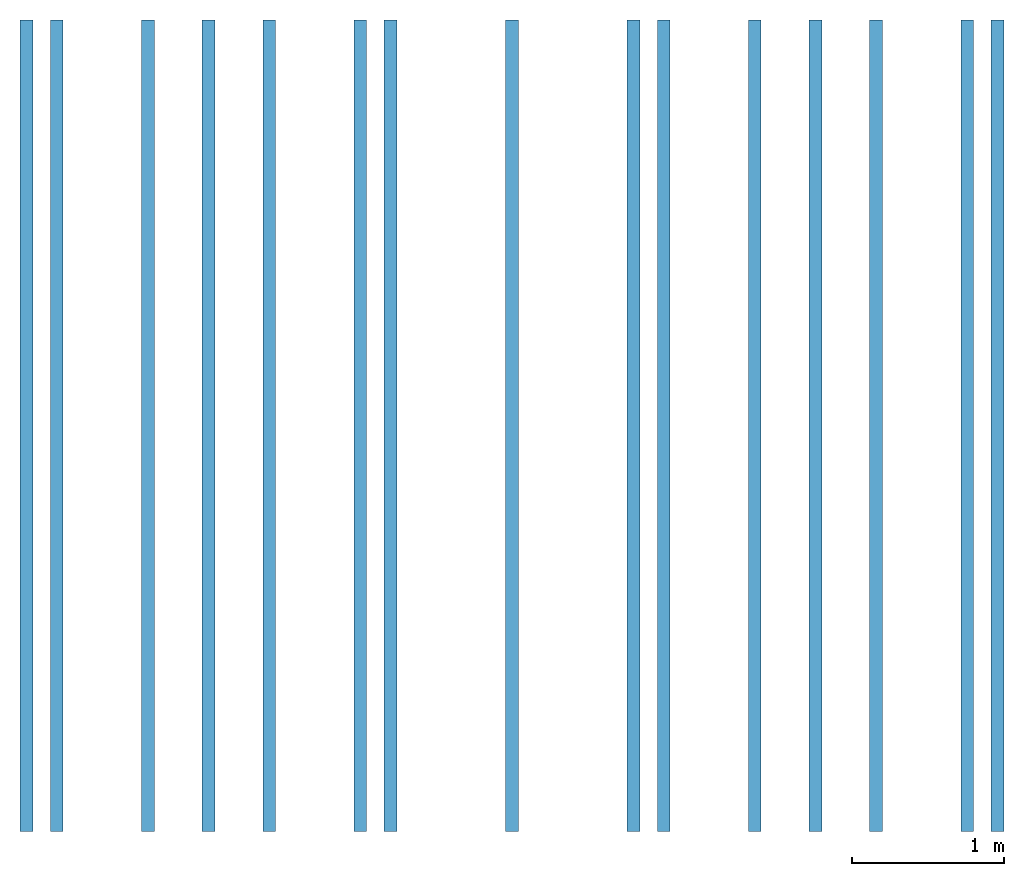
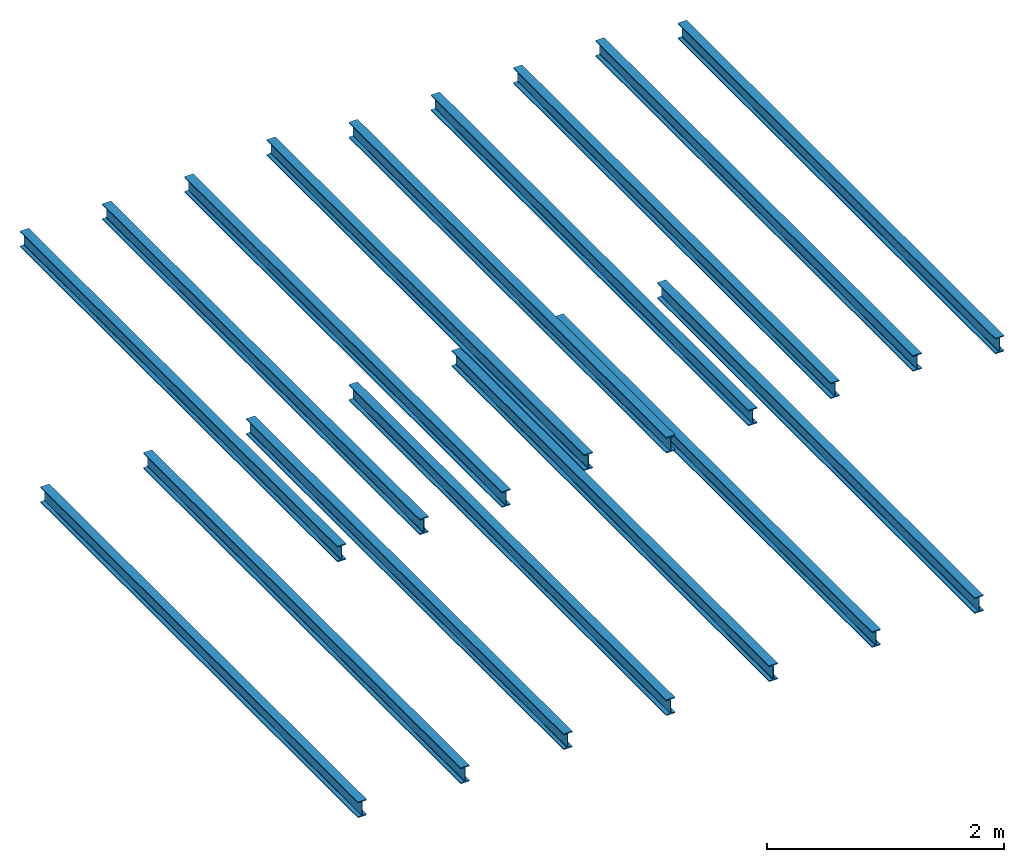
# One storey: 16 beams.
"""IFC2X3 building model written with IfcOpenShell, lengths in millimetres."""

from ifc_helpers import new_model, entity, si_unit, converted_unit, derived_unit, direction, frame, frame_2d, origin, place, context, subcontext, project, spatial, i_section, extrude, material, element, save


model = new_model("IFC2X3")

# Units and contexts
model_context = context("Model", 3, precision=0.01, world=origin(), true_north=direction((6.12303176911189e-17, 1.0)))
body_context = subcontext(model_context, "Body", "Model", "MODEL_VIEW")
ifc_project = project(units=[si_unit("LENGTHUNIT", "METRE", prefix="MILLI"), si_unit("AREAUNIT", "SQUARE_METRE"), si_unit("VOLUMEUNIT", "CUBIC_METRE"), converted_unit("PLANEANGLEUNIT", "DEGREE", entity("IfcRatioMeasure", 0.0174532925199433), si_unit("PLANEANGLEUNIT", "RADIAN"), dimensions=[0, 0, 0, 0, 0, 0, 0]), si_unit("MASSUNIT", "GRAM", prefix="KILO"), si_unit("TIMEUNIT", "SECOND"), si_unit("FREQUENCYUNIT", "HERTZ"), si_unit("THERMODYNAMICTEMPERATUREUNIT", "DEGREE_CELSIUS"), derived_unit("THERMALTRANSMITTANCEUNIT", [(si_unit("MASSUNIT", "GRAM", prefix="KILO"), 1), (si_unit("THERMODYNAMICTEMPERATUREUNIT", "KELVIN"), -1), (si_unit("TIMEUNIT", "SECOND"), -3)]), derived_unit("VOLUMETRICFLOWRATEUNIT", [(si_unit("LENGTHUNIT", "METRE"), 3), (si_unit("TIMEUNIT", "SECOND"), -1)]), si_unit("ELECTRICCURRENTUNIT", "AMPERE"), si_unit("ELECTRICVOLTAGEUNIT", "VOLT"), si_unit("POWERUNIT", "WATT"), si_unit("FORCEUNIT", "NEWTON", prefix="KILO"), si_unit("ILLUMINANCEUNIT", "LUX"), si_unit("LUMINOUSFLUXUNIT", "LUMEN"), si_unit("LUMINOUSINTENSITYUNIT", "CANDELA"), derived_unit("USERDEFINED", [(si_unit("MASSUNIT", "GRAM", prefix="KILO"), -1), (si_unit("LENGTHUNIT", "METRE"), -2), (si_unit("TIMEUNIT", "SECOND"), 3), (si_unit("LUMINOUSFLUXUNIT", "LUMEN"), 1)]), derived_unit("LINEARVELOCITYUNIT", [(si_unit("LENGTHUNIT", "METRE"), 1), (si_unit("TIMEUNIT", "SECOND"), -1)]), si_unit("PRESSUREUNIT", "PASCAL"), derived_unit("USERDEFINED", [(si_unit("LENGTHUNIT", "METRE"), -2), (si_unit("MASSUNIT", "GRAM", prefix="KILO"), 1), (si_unit("TIMEUNIT", "SECOND"), -2)])], contexts=[model_context])

# Site, building, storey
site_placement = place(None, origin())
site = spatial("IfcSite", under=ifc_project, at=site_placement, CompositionType="ELEMENT")
building_placement = place(site_placement, origin())
building = spatial("IfcBuilding", under=site, at=building_placement, CompositionType="ELEMENT")
storey_placement = place(building_placement, frame((0.0, 0.0, 2800.0)))
storey = spatial("IfcBuildingStorey", under=building, at=storey_placement, CompositionType="ELEMENT", Elevation=2800.0)

# Beams
ifc_material = material(Name="ocel 43-275")
beam_1_placement = place(storey_placement, frame((-5256.25586013304, 3654.82537555829, 0.0), z_axis=(0.0, 0.0, 1.0), x_axis=(0.0, -1.0, 0.0)))
element("IfcBeam", 1, at=beam_1_placement, inside=storey, material=ifc_material, context=body_context, shape_type="SweptSolid", body=[
    extrude(i_section(OverallWidth=85.0000000000002, OverallDepth=163.4, WebThickness=5.99999999999972, FlangeThickness=10.2000000000007, FilletRadius=8.90000000000008, at=frame_2d((1.35003119794419e-13, 1.08357767203415e-12), x_axis=(0.0, 1.0))), frame((0.0, 0.0, -281.700000000009), z_axis=(1.0, 0.0, 0.0), x_axis=(0.0, 0.0, -1.0)), (0.0, 0.0, 1.0), 5348.8),
])
beam_2_placement = place(storey_placement, frame((-6256.25586013304, 3654.82537555829, 0.0), z_axis=(0.0, 0.0, 1.0), x_axis=(0.0, -1.0, 0.0)))
element("IfcBeam", 2, at=beam_2_placement, inside=storey, material=ifc_material, context=body_context, shape_type="SweptSolid", body=[
    extrude(i_section(OverallWidth=85.0000000000002, OverallDepth=163.4, WebThickness=5.99999999999972, FlangeThickness=10.2000000000007, FilletRadius=8.90000000000008, at=frame_2d((1.35003119794419e-13, 0.0), x_axis=(0.0, 1.0))), frame((0.0, 0.0, -281.700000000009), z_axis=(1.0, 0.0, 0.0), x_axis=(0.0, 0.0, -1.0)), (0.0, 0.0, 1.0), 5348.8),
])
beam_3_placement = place(storey_placement, frame((-7256.25586013304, 3654.82537555829, 0.0), z_axis=(0.0, 0.0, 1.0), x_axis=(0.0, -1.0, 0.0)))
element("IfcBeam", 3, at=beam_3_placement, inside=storey, material=ifc_material, context=body_context, shape_type="SweptSolid", body=[
    extrude(i_section(OverallWidth=85.0000000000002, OverallDepth=163.4, WebThickness=5.99999999999972, FlangeThickness=10.2000000000007, FilletRadius=8.90000000000008, at=frame_2d((1.35003119794419e-13, -1.08357767203415e-12), x_axis=(0.0, 1.0))), frame((0.0, 0.0, -281.700000000009), z_axis=(1.0, 0.0, 0.0), x_axis=(0.0, 0.0, -1.0)), (0.0, 0.0, 1.0), 5348.8),
])
for number, where, z_axis, x_axis in (
    (4, (-8256.25586013304, 3654.82537555829, 0.0), (0.0, 0.0, 1.0), (0.0, -1.0, 0.0)),
    (5, (-9256.25586013304, 3654.82537555829, 0.0), (0.0, 0.0, 1.0), (0.0, -1.0, 0.0)),
):
    element("IfcBeam", number, at=place(storey_placement, frame(where, z_axis=z_axis, x_axis=x_axis)), inside=storey, material=ifc_material, context=body_context, shape_type="SweptSolid", body=[
        extrude(i_section(OverallWidth=85.0000000000002, OverallDepth=163.4, WebThickness=5.99999999999972, FlangeThickness=10.2000000000007, FilletRadius=8.90000000000008, at=frame_2d((1.35003119794419e-13, 0.0), x_axis=(0.0, 1.0))), frame((0.0, 0.0, -281.700000000009), z_axis=(1.0, 0.0, 0.0), x_axis=(0.0, 0.0, -1.0)), (0.0, 0.0, 1.0), 5348.8),
    ])
beam_4_placement = place(storey_placement, frame((-10256.255860133, 3654.82537555829, 0.0), z_axis=(0.0, 0.0, 1.0), x_axis=(0.0, -1.0, 0.0)))
element("IfcBeam", 6, at=beam_4_placement, inside=storey, material=ifc_material, context=body_context, shape_type="SweptSolid", body=[
    extrude(i_section(OverallWidth=85.0000000000002, OverallDepth=163.4, WebThickness=6.0000000000008, FlangeThickness=10.2000000000007, FilletRadius=8.90000000000053, at=frame_2d((1.35003119794419e-13, -1.08357767203415e-12), x_axis=(0.0, 1.0))), frame((0.0, 0.0, -281.700000000009), z_axis=(1.0, 0.0, 0.0), x_axis=(0.0, 0.0, -1.0)), (0.0, 0.0, 1.0), 5348.8),
])
beam_5_placement = place(storey_placement, frame((-11256.255860133, 3654.82537555829, 0.0), z_axis=(0.0, 0.0, 1.0), x_axis=(0.0, -1.0, 0.0)))
element("IfcBeam", 7, at=beam_5_placement, inside=storey, material=ifc_material, context=body_context, shape_type="SweptSolid", body=[
    extrude(i_section(OverallWidth=85.0000000000002, OverallDepth=163.4, WebThickness=6.0000000000008, FlangeThickness=10.2000000000007, FilletRadius=8.90000000000053, at=frame_2d((1.35003119794419e-13, 1.08357767203415e-12), x_axis=(0.0, 1.0))), frame((0.0, 0.0, -281.700000000009), z_axis=(1.0, 0.0, 0.0), x_axis=(0.0, 0.0, -1.0)), (0.0, 0.0, 1.0), 5348.8),
])
beam_6_placement = place(storey_placement, frame((-5056.25586013304, 3654.82537555829, 0.0), z_axis=(0.0, 0.0, 1.0), x_axis=(0.0, -1.0, 0.0)))
element("IfcBeam", 8, at=beam_6_placement, inside=storey, material=ifc_material, context=body_context, shape_type="SweptSolid", body=[
    extrude(i_section(OverallWidth=85.0000000000002, OverallDepth=163.4, WebThickness=5.99999999999972, FlangeThickness=10.2000000000009, FilletRadius=8.89999999999975, at=frame_2d((1.08002495835535e-12, -1.08357767203415e-12), x_axis=(0.0, 1.0))), frame((0.0, 0.0, 2318.29999999999), z_axis=(1.0, 0.0, 0.0), x_axis=(0.0, 0.0, -1.0)), (0.0, 0.0, 1.0), 5348.8),
])
for number, where, z_axis, x_axis in (
    (9, (-5856.25586013304, 3654.82537555829, 0.0), (0.0, 0.0, 1.0), (0.0, -1.0, 0.0)),
    (10, (-6656.25586013304, 3654.82537555829, 0.0), (0.0, 0.0, 1.0), (0.0, -1.0, 0.0)),
):
    element("IfcBeam", number, at=place(storey_placement, frame(where, z_axis=z_axis, x_axis=x_axis)), inside=storey, material=ifc_material, context=body_context, shape_type="SweptSolid", body=[
        extrude(i_section(OverallWidth=85.0000000000002, OverallDepth=163.4, WebThickness=5.99999999999972, FlangeThickness=10.2000000000009, FilletRadius=8.89999999999975, at=frame_2d((1.08002495835535e-12, 0.0), x_axis=(0.0, 1.0))), frame((0.0, 0.0, 2418.29999999999), z_axis=(1.0, 0.0, 0.0), x_axis=(0.0, 0.0, -1.0)), (0.0, 0.0, 1.0), 5348.8),
    ])
beam_7_placement = place(storey_placement, frame((-7456.25586013304, 3654.82537555829, 0.0), z_axis=(0.0, 0.0, 1.0), x_axis=(0.0, -1.0, 0.0)))
element("IfcBeam", 11, at=beam_7_placement, inside=storey, material=ifc_material, context=body_context, shape_type="SweptSolid", body=[
    extrude(i_section(OverallWidth=85.0000000000002, OverallDepth=163.4, WebThickness=5.99999999999972, FlangeThickness=10.2000000000009, FilletRadius=8.89999999999975, at=frame_2d((1.08002495835535e-12, 2.16715534406831e-12), x_axis=(0.0, 1.0))), frame((0.0, 0.0, 2418.29999999999), z_axis=(1.0, 0.0, 0.0), x_axis=(0.0, 0.0, -1.0)), (0.0, 0.0, 1.0), 5348.8),
])
beam_8_placement = place(storey_placement, frame((-8256.25586013304, 3654.82537555829, 0.0), z_axis=(0.0, 0.0, 1.0), x_axis=(0.0, -1.0, 0.0)))
element("IfcBeam", 12, at=beam_8_placement, inside=storey, material=ifc_material, context=body_context, shape_type="SweptSolid", body=[
    extrude(i_section(OverallWidth=85.0000000000002, OverallDepth=163.4, WebThickness=5.99999999999972, FlangeThickness=10.2000000000009, FilletRadius=8.89999999999975, at=frame_2d((1.08002495835535e-12, 0.0), x_axis=(0.0, 1.0))), frame((0.0, 0.0, 2418.29999999999), z_axis=(1.0, 0.0, 0.0), x_axis=(0.0, 0.0, -1.0)), (0.0, 0.0, 1.0), 5348.8),
])
beam_9_placement = place(storey_placement, frame((-9056.25586013304, 3654.82537555829, 0.0), z_axis=(0.0, 0.0, 1.0), x_axis=(0.0, -1.0, 0.0)))
element("IfcBeam", 13, at=beam_9_placement, inside=storey, material=ifc_material, context=body_context, shape_type="SweptSolid", body=[
    extrude(i_section(OverallWidth=85.0000000000002, OverallDepth=163.4, WebThickness=5.99999999999972, FlangeThickness=10.2000000000009, FilletRadius=8.89999999999975, at=frame_2d((0.0, 3.24718030242366e-12), x_axis=(0.0, 1.0))), frame((0.0, 0.0, 2518.29999999999), z_axis=(1.0, 0.0, 0.0), x_axis=(0.0, 0.0, -1.0)), (0.0, 0.0, 1.0), 5348.8),
])
beam_10_placement = place(storey_placement, frame((-9856.25586013304, 3654.82537555829, 0.0), z_axis=(0.0, 0.0, 1.0), x_axis=(0.0, -1.0, 0.0)))
element("IfcBeam", 14, at=beam_10_placement, inside=storey, material=ifc_material, context=body_context, shape_type="SweptSolid", body=[
    extrude(i_section(OverallWidth=85.0000000000002, OverallDepth=163.4, WebThickness=6.0000000000008, FlangeThickness=10.2000000000009, FilletRadius=8.90000000000016, at=frame_2d((1.08002495835535e-12, -1.08357767203415e-12), x_axis=(0.0, 1.0))), frame((0.0, 0.0, 2418.29999999999), z_axis=(1.0, 0.0, 0.0), x_axis=(0.0, 0.0, -1.0)), (0.0, 0.0, 1.0), 5348.8),
])
for number, where, z_axis, x_axis in (
    (15, (-10656.255860133, 3654.82537555829, 0.0), (0.0, 0.0, 1.0), (0.0, -1.0, 0.0)),
    (16, (-11456.255860133, 3654.82537555829, 0.0), (0.0, 0.0, 1.0), (0.0, -1.0, 0.0)),
):
    element("IfcBeam", number, at=place(storey_placement, frame(where, z_axis=z_axis, x_axis=x_axis)), inside=storey, material=ifc_material, context=body_context, shape_type="SweptSolid", body=[
        extrude(i_section(OverallWidth=85.0000000000002, OverallDepth=163.4, WebThickness=6.0000000000008, FlangeThickness=10.2000000000009, FilletRadius=8.90000000000016, at=frame_2d((1.08002495835535e-12, 1.08357767203415e-12), x_axis=(0.0, 1.0))), frame((0.0, 0.0, 2418.29999999999), z_axis=(1.0, 0.0, 0.0), x_axis=(0.0, 0.0, -1.0)), (0.0, 0.0, 1.0), 5348.8),
    ])

save(model, "model.ifc")
